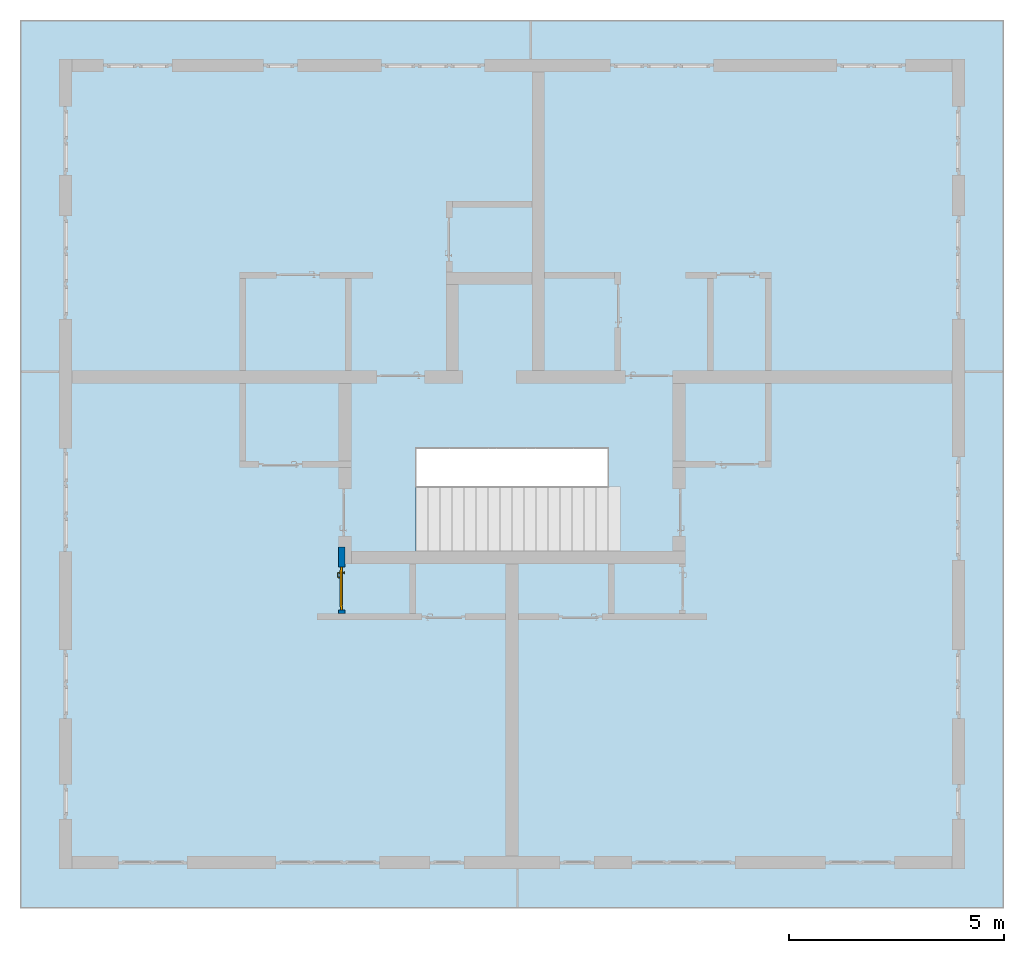
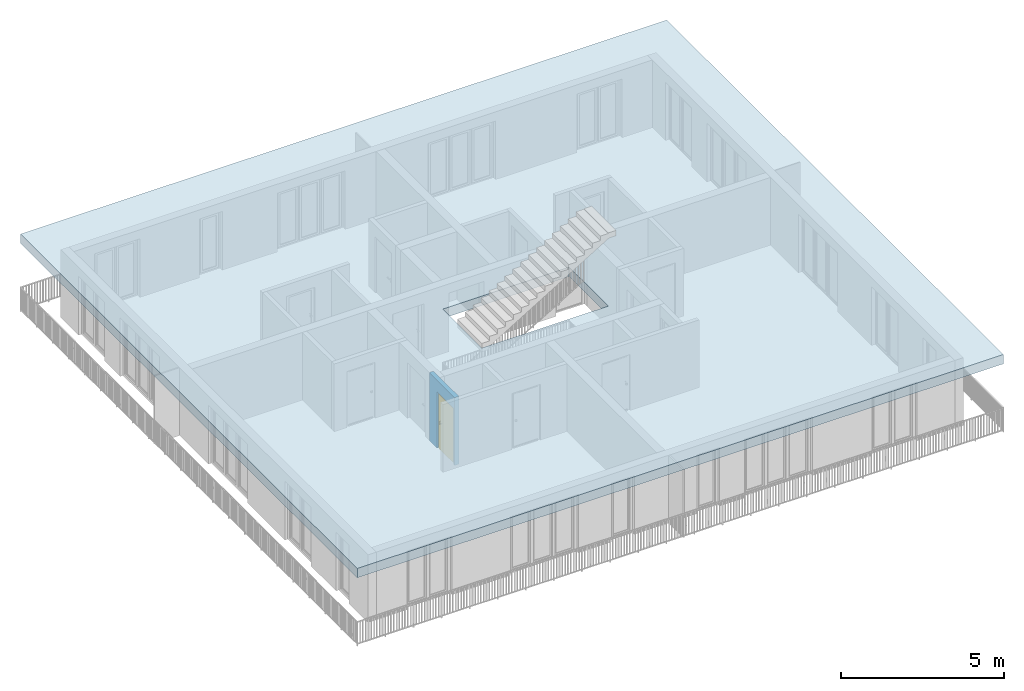
# One storey, part 1 of 48: 1 door, 1 slab, 1 wall, 1 opening.
"""IFC4 building model written with IfcOpenShell, lengths in metres."""

from ifc_helpers import new_model, entity, si_unit, converted_unit, derived_unit, direction, frame, origin_with_axes, place, context, subcontext, project, spatial, polygons, source, transform, mapped, material, type_object, element, fill, save


model = new_model("IFC4")

# Units and contexts
model_context = context("Model", 3, precision=1e-05, world=origin_with_axes(), true_north=direction((0.0, 1.0)))
body_context = subcontext(model_context, "Body", "Model", "MODEL_VIEW")
ifc_project = project(units=[si_unit("LENGTHUNIT", "METRE"), si_unit("AREAUNIT", "SQUARE_METRE"), si_unit("VOLUMEUNIT", "CUBIC_METRE"), converted_unit("PLANEANGLEUNIT", "DEGREE", entity("IfcPlaneAngleMeasure", 0.0174532925199), si_unit("PLANEANGLEUNIT", "RADIAN"), dimensions=[0, 0, 0, 0, 0, 0, 0]), converted_unit("TIMEUNIT", "Year", entity("IfcTimeMeasure", 31556926.0), si_unit("TIMEUNIT", "SECOND"), dimensions=[0, 0, 1, 0, 0, 0, 0]), si_unit("MASSUNIT", "GRAM", prefix="KILO"), si_unit("THERMODYNAMICTEMPERATUREUNIT", "DEGREE_CELSIUS"), si_unit("LUMINOUSINTENSITYUNIT", "LUMEN"), si_unit("ENERGYUNIT", "JOULE", prefix="MEGA"), derived_unit("THERMALCONDUCTANCEUNIT", [(si_unit("POWERUNIT", "WATT"), 1), (si_unit("LENGTHUNIT", "METRE"), -1), (si_unit("THERMODYNAMICTEMPERATUREUNIT", "KELVIN"), -1)]), derived_unit("SPECIFICHEATCAPACITYUNIT", [(si_unit("ENERGYUNIT", "JOULE"), 1), (si_unit("MASSUNIT", "GRAM", prefix="KILO"), -1), (si_unit("THERMODYNAMICTEMPERATUREUNIT", "KELVIN"), -1)]), derived_unit("MASSDENSITYUNIT", [(si_unit("MASSUNIT", "GRAM", prefix="KILO"), 1), (si_unit("VOLUMEUNIT", "CUBIC_METRE"), -1)])], contexts=[model_context])

# Site, building, storey, space
site_placement = place(None, origin_with_axes())
site = spatial("IfcSite", under=ifc_project, at=site_placement, CompositionType="ELEMENT")
building_placement = place(site_placement, origin_with_axes())
building = spatial("IfcBuilding", under=site, at=building_placement, CompositionType="ELEMENT")
storey_placement = place(building_placement, frame((0.0, 0.0, 3.4), z_axis=(0.0, 0.0, 1.0), x_axis=(1.0, 0.0, 0.0)))
storey = spatial("IfcBuildingStorey", under=building, at=storey_placement, Name="1. Geschoss", CompositionType="ELEMENT", Elevation=3.4)
space_placement = place(storey_placement, frame((-0.742199380397, 1.67118776896, 0.0), z_axis=(0.0, 0.0, 1.0), x_axis=(0.0, 1.0, 0.0)))
space = spatial("IfcSpace", under=storey, at=space_placement, CompositionType="ELEMENT", PredefinedType="INTERNAL")

# Slab
ifc_material = material()
slab_type = type_object("IfcSlabType", Name="350", PredefinedType="NOTDEFINED")
slab_placement = place(space_placement, frame((-12.5, 11.9, 2.89), z_axis=(0.0, 0.0, 1.0), x_axis=(0.0, -1.0, 0.0)))
element("IfcSlab", 1, at=slab_placement, inside=space, type_object=slab_type, material=ifc_material, Name="Decke-001", PredefinedType="NOTDEFINED", context=body_context, shape_type="Tessellation", body=[
    polygons([(0.0, 0.0, 0.0), (0.0, 0.0, -0.35), (22.88, 0.0, -0.35), (22.88, 0.0, 0.0), (0.0, 20.65, 0.0), (0.0, 20.65, -0.35), (22.88, 20.65, -0.35), (13.68, 8.3, -0.35), (13.68, 10.7, -0.35), (9.2, 10.7, -0.35), (9.2, 8.3, -0.35), (22.88, 20.65, 0.0), (9.2, 10.7, 0.0), (13.68, 10.7, 0.0), (13.68, 8.3, 0.0), (9.2, 8.3, 0.0)], [[[1, 2, 3, 4]], [[5, 6, 2, 1]], [[3, 2, 6, 7], [8, 9, 10, 11]], [[4, 3, 7, 12]], [[5, 1, 4, 12], [13, 14, 15, 16]], [[12, 7, 6, 5]], [[14, 9, 8, 15]], [[13, 10, 9, 14]], [[16, 11, 10, 13]], [[15, 8, 11, 16]]], closed=True),
])

# Wall, opening, door
wall_type = type_object("IfcWallType", Name="150", PredefinedType="NOTDEFINED")
wall_placement = place(storey_placement, frame((-5.2421993804, -4.12881223104, 0.0), z_axis=(0.0, 0.0, 1.0), x_axis=(0.0, 1.0, 0.0)))
wall = element("IfcWall", 2, at=wall_placement, inside=storey, type_object=wall_type, material=ifc_material, Name="Wand-002", PredefinedType="NOTDEFINED", context=body_context, shape_type="Tessellation", body=[
    polygons([(0.225, -0.15, 2.1), (0.225, 0.0, 2.1), (1.225, 0.0, 2.1), (1.225, -0.15, 2.1), (0.225, -0.1, 0.0), (0.225, 0.0, 0.0), (0.225, -0.15, 0.0), (0.15, 0.0, 0.0), (0.15, 0.0, 2.54), (1.7, 0.0, 2.54), (1.7, 0.0, 0.0), (1.225, 0.0, 0.0), (1.225, -0.1, 0.0), (1.225, -0.15, 0.0), (1.7, -0.15, 2.54), (0.15, -0.15, 2.54), (0.15, -0.15, 0.0), (1.7, -0.15, 0.0)], [[[1, 2, 3, 4]], [[5, 6, 2, 1, 7]], [[2, 6, 8, 9, 10, 11, 12, 3]], [[4, 3, 12, 13, 14]], [[15, 16, 17, 7, 1, 4, 14, 18]], [[6, 5, 7, 17, 8]], [[9, 8, 17, 16]], [[15, 10, 9, 16]], [[15, 18, 11, 10]], [[13, 12, 11, 18, 14]]], closed=True),
])
opening_placement = place(wall_placement, frame((0.725, 0.0, 0.0), z_axis=(0.0, 0.0, 1.0), x_axis=(1.0, 0.0, 0.0)))
opening = element("IfcOpeningElement", 3, at=opening_placement, cuts=wall, context=body_context, identifier="Reference", shape_type="Tessellation", body=[
    polygons([(0.5, -0.1, 0.0), (0.5, -0.1, 2.1), (0.5, -0.151, 2.1), (0.5, -0.151, 0.0), (0.5, 0.001, 0.0), (0.5, 0.001, 2.1), (-0.5, -0.1, 2.1), (-0.5, -0.151, 2.1), (-0.5, 0.001, 2.1), (-0.5, -0.151, 0.0), (-0.5, -0.1, 0.0), (-0.5, 0.001, 0.0)], [[[1, 2, 3, 4]], [[2, 1, 5, 6]], [[7, 8, 3, 2, 6, 9]], [[8, 10, 4, 3]], [[1, 4, 10, 11, 12, 5]], [[6, 5, 12, 9]], [[7, 11, 10, 8]], [[11, 7, 9, 12]]], closed=True),
])
door_type = type_object("IfcDoorType", Name="Eingang 01 1-Fl 26", OperationType="SINGLE_SWING_LEFT", PredefinedType="DOOR")
shared_shape = source(origin_with_axes(), body_context, "Body", "Tessellation", [
    polygons([(-0.5, -0.05, 0.0), (-0.5, -0.05, 2.1), (-0.5, -0.03, 2.1), (-0.5, -0.03, 0.0), (-0.4, -0.05, 0.0), (-0.4, -0.05, 2.0), (-0.1301, -0.05, 2.0), (-0.0001, -0.05, 2.0), (0.4, -0.05, 2.0), (0.4, -0.05, 0.0), (0.5, -0.05, 0.0), (0.5, -0.05, 2.1), (0.5, -0.03, 2.1), (0.5, -0.03, 0.0), (0.4, -0.03, 0.0), (0.4, -0.03, 2.0), (-0.0001, -0.03, 2.0), (-0.1301, -0.03, 2.0), (-0.4, -0.03, 2.0), (-0.4, -0.03, 0.0)], [[[1, 2, 3, 4]], [[1, 5, 6, 7, 8, 9, 10, 11, 12, 2]], [[2, 12, 13, 3]], [[4, 3, 13, 14, 15, 16, 17, 18, 19, 20]], [[5, 1, 4, 20]], [[6, 5, 20, 19]], [[7, 6, 19, 18]], [[8, 7, 18, 17]], [[9, 8, 17, 16]], [[10, 9, 16, 15]], [[11, 10, 15, 14]], [[12, 11, 14, 13]]], closed=True),
    polygons([(-0.5, -0.03, 0.0), (-0.5, -0.03, 2.1), (-0.5, 0.0, 2.1), (-0.5, 0.0, 0.0), (-0.43, -0.03, 0.0), (-0.43, -0.03, 2.03), (-0.1001, -0.03, 2.03), (-0.0301, -0.03, 2.03), (0.43, -0.03, 2.03), (0.43, -0.03, 0.0), (0.5, -0.03, 0.0), (0.5, -0.03, 2.1), (0.5, 0.0, 2.1), (0.5, 0.0, 0.0), (0.43, 0.0, 0.0), (0.43, 0.0, 2.03), (-0.0301, 0.0, 2.03), (-0.1001, 0.0, 2.03), (-0.43, 0.0, 2.03), (-0.43, 0.0, 0.0)], [[[1, 2, 3, 4]], [[1, 5, 6, 7, 8, 9, 10, 11, 12, 2]], [[2, 12, 13, 3]], [[4, 3, 13, 14, 15, 16, 17, 18, 19, 20]], [[5, 1, 4, 20]], [[6, 5, 20, 19]], [[7, 6, 19, 18]], [[8, 7, 18, 17]], [[9, 8, 17, 16]], [[10, 9, 16, 15]], [[11, 10, 15, 14]], [[12, 11, 14, 13]]], closed=True),
    polygons([(-0.43, 0.01, 0.0), (-0.43, 0.01, 2.03), (0.43, 0.01, 2.03), (0.43, 0.01, 0.0), (-0.43, -0.03, 0.0), (-0.43, -0.03, 2.03), (0.43, -0.03, 2.03), (0.43, -0.03, 0.0)], [[[1, 2, 3, 4]], [[1, 5, 6, 2]], [[2, 6, 7, 3]], [[3, 7, 8, 4]], [[4, 8, 5, 1]], [[8, 7, 6, 5]]], closed=True),
    polygons([(-0.395, -0.05, 0.0), (0.395, -0.05, 0.0), (0.395, -0.05, 0.05), (-0.395, -0.05, 0.05), (-0.395, -0.03, 0.0), (0.395, -0.03, 0.0), (0.395, -0.03, 0.07), (0.395, -0.035, 0.07), (-0.395, -0.035, 0.07), (-0.395, -0.03, 0.07)], [[[1, 2, 3, 4]], [[5, 6, 2, 1]], [[2, 6, 7, 8, 3]], [[4, 3, 8, 9]], [[1, 4, 9, 10, 5]], [[10, 7, 6, 5]], [[9, 8, 7, 10]]], closed=True),
    polygons([(0.3835, 0.02, 1.0733826859), (0.37, 0.02, 1.077), (0.37, 0.0199, 1.077), (0.3835, 0.0199, 1.0733826859), (0.393382685902, 0.02, 1.0635), (0.397, 0.02, 1.05), (0.393382685902, 0.02, 1.0365), (0.3835, 0.02, 1.0266173141), (0.37, 0.02, 1.023), (0.3565, 0.02, 1.0266173141), (0.346617314098, 0.02, 1.0365), (0.343, 0.02, 1.05), (0.346617314098, 0.02, 1.0635), (0.3565, 0.02, 1.0733826859), (0.3565, 0.0199, 1.0733826859), (0.37, 0.0101, 1.077), (0.3835, 0.0101, 1.0733826859), (0.393382685902, 0.0199, 1.0635), (0.397, 0.0199, 1.05), (0.393382685902, 0.0199, 1.0365), (0.3835, 0.0199, 1.0266173141), (0.37, 0.0199, 1.023), (0.3565, 0.0199, 1.0266173141), (0.346617314098, 0.0199, 1.0365), (0.343, 0.0199, 1.05), (0.346617314098, 0.0199, 1.0635), (0.3565, 0.0101, 1.0733826859), (0.37, 0.01, 1.077), (0.3835, 0.01, 1.0733826859), (0.393382685902, 0.0101, 1.0635), (0.397, 0.0101, 1.05), (0.393382685902, 0.0101, 1.0365), (0.3835, 0.0101, 1.0266173141), (0.37, 0.0101, 1.023), (0.3565, 0.0101, 1.0266173141), (0.346617314098, 0.0101, 1.0365), (0.343, 0.0101, 1.05), (0.346617314098, 0.0101, 1.0635), (0.3565, 0.01, 1.0733826859), (0.346617314098, 0.01, 1.0635), (0.343, 0.01, 1.05), (0.346617314098, 0.01, 1.0365), (0.3565, 0.01, 1.0266173141), (0.37, 0.01, 1.023), (0.3835, 0.01, 1.0266173141), (0.393382685902, 0.01, 1.0365), (0.397, 0.01, 1.05), (0.393382685902, 0.01, 1.0635)], [[[1, 2, 3, 4]], [[2, 1, 5, 6, 7, 8, 9, 10, 11, 12, 13, 14]], [[2, 14, 15, 3]], [[4, 3, 16, 17]], [[5, 1, 4, 18]], [[6, 5, 18, 19]], [[7, 6, 19, 20]], [[8, 7, 20, 21]], [[9, 8, 21, 22]], [[10, 9, 22, 23]], [[11, 10, 23, 24]], [[12, 11, 24, 25]], [[13, 12, 25, 26]], [[14, 13, 26, 15]], [[3, 15, 27, 16]], [[17, 16, 28, 29]], [[18, 4, 17, 30]], [[19, 18, 30, 31]], [[20, 19, 31, 32]], [[21, 20, 32, 33]], [[22, 21, 33, 34]], [[23, 22, 34, 35]], [[24, 23, 35, 36]], [[25, 24, 36, 37]], [[26, 25, 37, 38]], [[15, 26, 38, 27]], [[16, 27, 39, 28]], [[28, 39, 40, 41, 42, 43, 44, 45, 46, 47, 48, 29]], [[30, 17, 29, 48]], [[31, 30, 48, 47]], [[32, 31, 47, 46]], [[33, 32, 46, 45]], [[34, 33, 45, 44]], [[35, 34, 44, 43]], [[36, 35, 43, 42]], [[37, 36, 42, 41]], [[38, 37, 41, 40]], [[27, 38, 40, 39]]], closed=True),
    polygons([(0.362532169224, 0.019, 0.959692280177), (0.363279754556, 0.019, 0.961639806549), (0.35705, 0.019, 0.972430057958), (0.347569942042, 0.019, 0.96295), (0.365, 0.019, 0.952886751346), (0.365, 0.019, 0.9544), (0.362532169224, 0.02, 0.959692280177), (0.363279754556, 0.02, 0.961639806549), (0.364624817685, 0.02, 0.965143815798), (0.364624817685, 0.019, 0.965143815798), (0.37, 0.019, 0.967425445323), (0.37, 0.019, 0.9759), (0.357, 0.019, 0.972516660498), (0.347483339502, 0.019, 0.963), (0.365, 0.019, 0.95), (0.3441, 0.019, 0.95), (0.365, 0.019, 0.947113248654), (0.365, 0.019, 0.941339745962), (0.365, 0.019, 0.9375), (0.365, 0.02, 0.9375), (0.365, 0.02, 0.941339745962), (0.365, 0.02, 0.947113248654), (0.365, 0.02, 0.95), (0.365, 0.02, 0.952886751346), (0.365, 0.02, 0.9544), (0.346703916638, 0.02, 0.96345), (0.35655, 0.02, 0.973296083362), (0.37, 0.02, 0.9769), (0.37, 0.02, 0.967425445323), (0.375375182315, 0.019, 0.965143815798), (0.376720245444, 0.019, 0.961639806549), (0.38295, 0.019, 0.972430057958), (0.37, 0.019, 0.976), (0.357, 0.0189, 0.972516660498), (0.347483339502, 0.0189, 0.963), (0.344, 0.019, 0.95), (0.347569942042, 0.019, 0.93705), (0.35705, 0.019, 0.927569942042), (0.37, 0.019, 0.9241), (0.37, 0.019, 0.9325), (0.366464466094, 0.019, 0.933964466094), (0.366464466094, 0.02, 0.933964466094), (0.37, 0.02, 0.9231), (0.35655, 0.02, 0.926703916638), (0.37, 0.02, 0.9325), (0.346703916638, 0.02, 0.93655), (0.3431, 0.02, 0.95), (0.346617314098, 0.02, 0.9635), (0.3565, 0.02, 0.973382685902), (0.37, 0.02, 0.977), (0.375375182315, 0.02, 0.965143815798), (0.38345, 0.02, 0.973296083362), (0.376720245444, 0.02, 0.961639806549), (0.377467830776, 0.02, 0.959692280177), (0.377467830776, 0.019, 0.959692280177), (0.375, 0.019, 0.9544), (0.375, 0.019, 0.952886751346), (0.392430057958, 0.019, 0.96295), (0.383, 0.019, 0.972516660498), (0.37, 0.0189, 0.976), (0.357, 0.0101, 0.972516660498), (0.347483339502, 0.0101, 0.963), (0.344, 0.0189, 0.95), (0.347483339502, 0.019, 0.937), (0.357, 0.019, 0.927483339502), (0.37, 0.019, 0.924), (0.38295, 0.019, 0.927569942042), (0.375, 0.019, 0.941339745962), (0.375, 0.019, 0.9375), (0.373535533906, 0.019, 0.933964466094), (0.37, 0.02, 0.923), (0.3565, 0.02, 0.926617314098), (0.38345, 0.02, 0.926703916638), (0.373535533906, 0.02, 0.933964466094), (0.375, 0.02, 0.9375), (0.375, 0.02, 0.941339745962), (0.346617314098, 0.02, 0.9365), (0.343, 0.02, 0.95), (0.346617314098, 0.0199, 0.9635), (0.3565, 0.0199, 0.973382685902), (0.37, 0.0199, 0.977), (0.3835, 0.02, 0.973382685902), (0.393296083362, 0.02, 0.96345), (0.375, 0.02, 0.952886751346), (0.375, 0.02, 0.9544), (0.375, 0.02, 0.95), (0.375, 0.02, 0.947113248654), (0.375, 0.019, 0.947113248654), (0.375, 0.019, 0.95), (0.3959, 0.019, 0.95), (0.392516660498, 0.019, 0.963), (0.383, 0.0189, 0.972516660498), (0.37, 0.0101, 0.976), (0.357, 0.01, 0.972516660498), (0.347483339502, 0.01, 0.963), (0.344, 0.0101, 0.95), (0.347483339502, 0.0189, 0.937), (0.357, 0.0189, 0.927483339502), (0.37, 0.0189, 0.924), (0.383, 0.019, 0.927483339502), (0.392430057958, 0.019, 0.93705), (0.37, 0.0199, 0.923), (0.3565, 0.0199, 0.926617314098), (0.3835, 0.02, 0.926617314098), (0.393296083362, 0.02, 0.93655), (0.346617314098, 0.0199, 0.9365), (0.343, 0.0199, 0.95), (0.346617314098, 0.0101, 0.9635), (0.3565, 0.0101, 0.973382685902), (0.37, 0.0101, 0.977), (0.3835, 0.0199, 0.973382685902), (0.393382685902, 0.02, 0.9635), (0.3969, 0.02, 0.95), (0.396, 0.019, 0.95), (0.392516660498, 0.0189, 0.963), (0.383, 0.0101, 0.972516660498), (0.37, 0.01, 0.976), (0.35695, 0.01, 0.972603263039), (0.347396736961, 0.01, 0.96305), (0.344, 0.01, 0.95), (0.347483339502, 0.0101, 0.937), (0.357, 0.0101, 0.927483339502), (0.37, 0.0101, 0.924), (0.383, 0.0189, 0.927483339502), (0.392516660498, 0.019, 0.937), (0.37, 0.0101, 0.923), (0.3565, 0.0101, 0.926617314098), (0.3835, 0.0199, 0.926617314098), (0.393382685902, 0.02, 0.9365), (0.346617314098, 0.0101, 0.9365), (0.343, 0.0101, 0.95), (0.346617314098, 0.01, 0.9635), (0.3565, 0.01, 0.973382685902), (0.37, 0.01, 0.977), (0.3835, 0.0101, 0.973382685902), (0.393382685902, 0.0199, 0.9635), (0.397, 0.02, 0.95), (0.396, 0.0189, 0.95), (0.392516660498, 0.0101, 0.963), (0.383, 0.01, 0.972516660498), (0.37, 0.01, 0.9761), (0.35655, 0.01, 0.973296083362), (0.346703916638, 0.01, 0.96345), (0.3439, 0.01, 0.95), (0.347483339502, 0.01, 0.937), (0.357, 0.01, 0.927483339502), (0.37, 0.01, 0.924), (0.383, 0.0101, 0.927483339502), (0.392516660498, 0.0189, 0.937), (0.37, 0.01, 0.923), (0.3565, 0.01, 0.926617314098), (0.3835, 0.0101, 0.926617314098), (0.393382685902, 0.0199, 0.9365), (0.346617314098, 0.01, 0.9365), (0.343, 0.01, 0.95), (0.37, 0.01, 0.9769), (0.3835, 0.01, 0.973382685902), (0.393382685902, 0.0101, 0.9635), (0.397, 0.0199, 0.95), (0.396, 0.0101, 0.95), (0.392516660498, 0.01, 0.963), (0.38305, 0.01, 0.972603263039), (0.3431, 0.01, 0.95), (0.347396736961, 0.01, 0.93695), (0.35695, 0.01, 0.927396736961), (0.37, 0.01, 0.9239), (0.383, 0.01, 0.927483339502), (0.392516660498, 0.0101, 0.937), (0.37, 0.01, 0.9231), (0.35655, 0.01, 0.926703916638), (0.3835, 0.01, 0.926617314098), (0.393382685902, 0.0101, 0.9365), (0.346703916638, 0.01, 0.93655), (0.38345, 0.01, 0.973296083362), (0.393382685902, 0.01, 0.9635), (0.397, 0.0101, 0.95), (0.396, 0.01, 0.95), (0.392603263039, 0.01, 0.96305), (0.38305, 0.01, 0.927396736961), (0.392516660498, 0.01, 0.937), (0.38345, 0.01, 0.926703916638), (0.393382685902, 0.01, 0.9365), (0.393296083362, 0.01, 0.96345), (0.397, 0.01, 0.95), (0.3961, 0.01, 0.95), (0.392603263039, 0.01, 0.93695), (0.393296083362, 0.01, 0.93655), (0.3969, 0.01, 0.95)], [[[1, 2, 3, 4, 5, 6]], [[1, 7, 8, 9, 10, 2]], [[10, 11, 12, 3, 2]], [[4, 3, 13, 14]], [[15, 5, 4, 16]], [[6, 5, 15, 17, 18, 19, 20, 21, 22, 23, 24, 25]], [[6, 25, 7, 1]], [[7, 25, 24, 26, 27, 8]], [[9, 8, 27, 28, 29]], [[10, 9, 29, 11]], [[30, 31, 32, 12, 11]], [[3, 12, 33, 13]], [[14, 13, 34, 35]], [[16, 4, 14, 36]], [[17, 15, 16, 37]], [[18, 17, 37, 38]], [[38, 39, 40, 41, 19, 18]], [[19, 41, 42, 20]], [[43, 44, 21, 20, 42, 45]], [[22, 21, 44, 46]], [[23, 22, 46, 47]], [[24, 23, 47, 26]], [[48, 49, 27, 26]], [[49, 50, 28, 27]], [[51, 29, 28, 52, 53]], [[11, 29, 51, 30]], [[30, 51, 53, 54, 55, 31]], [[55, 56, 57, 58, 32, 31]], [[12, 32, 59, 33]], [[13, 33, 60, 34]], [[35, 34, 61, 62]], [[36, 14, 35, 63]], [[37, 16, 36, 64]], [[38, 37, 64, 65]], [[39, 38, 65, 66]], [[39, 67, 68, 69, 70, 40]], [[41, 40, 45, 42]], [[71, 72, 44, 43]], [[73, 43, 45, 74, 75, 76]], [[72, 77, 46, 44]], [[77, 78, 47, 46]], [[78, 48, 26, 47]], [[79, 80, 49, 48]], [[80, 81, 50, 49]], [[50, 82, 52, 28]], [[54, 53, 52, 83, 84, 85]], [[55, 54, 85, 56]], [[85, 84, 86, 87, 76, 75, 69, 68, 88, 89, 57, 56]], [[57, 89, 90, 58]], [[32, 58, 91, 59]], [[33, 59, 92, 60]], [[34, 60, 93, 61]], [[62, 61, 94, 95]], [[63, 35, 62, 96]], [[64, 36, 63, 97]], [[65, 64, 97, 98]], [[66, 65, 98, 99]], [[67, 39, 66, 100]], [[88, 68, 67, 101]], [[70, 69, 75, 74]], [[40, 70, 74, 45]], [[102, 103, 72, 71]], [[104, 71, 43, 73]], [[76, 87, 105, 73]], [[103, 106, 77, 72]], [[106, 107, 78, 77]], [[107, 79, 48, 78]], [[108, 109, 80, 79]], [[109, 110, 81, 80]], [[81, 111, 82, 50]], [[82, 112, 83, 52]], [[86, 84, 83, 113]], [[87, 86, 113, 105]], [[89, 88, 101, 90]], [[58, 90, 114, 91]], [[59, 91, 115, 92]], [[60, 92, 116, 93]], [[61, 93, 117, 94]], [[95, 94, 118, 119]], [[96, 62, 95, 120]], [[97, 63, 96, 121]], [[98, 97, 121, 122]], [[99, 98, 122, 123]], [[100, 66, 99, 124]], [[101, 67, 100, 125]], [[126, 127, 103, 102]], [[128, 102, 71, 104]], [[129, 104, 73, 105]], [[127, 130, 106, 103]], [[130, 131, 107, 106]], [[131, 108, 79, 107]], [[132, 133, 109, 108]], [[133, 134, 110, 109]], [[110, 135, 111, 81]], [[111, 136, 112, 82]], [[112, 137, 113, 83]], [[137, 129, 105, 113]], [[90, 101, 125, 114]], [[91, 114, 138, 115]], [[92, 115, 139, 116]], [[93, 116, 140, 117]], [[94, 117, 141, 118]], [[119, 118, 142, 143]], [[120, 95, 119, 144]], [[121, 96, 120, 145]], [[122, 121, 145, 146]], [[123, 122, 146, 147]], [[124, 99, 123, 148]], [[125, 100, 124, 149]], [[150, 151, 127, 126]], [[152, 126, 102, 128]], [[153, 128, 104, 129]], [[151, 154, 130, 127]], [[154, 155, 131, 130]], [[155, 132, 108, 131]], [[143, 142, 133, 132]], [[142, 156, 134, 133]], [[134, 157, 135, 110]], [[135, 158, 136, 111]], [[136, 159, 137, 112]], [[159, 153, 129, 137]], [[114, 125, 149, 138]], [[115, 138, 160, 139]], [[116, 139, 161, 140]], [[117, 140, 162, 141]], [[118, 141, 156, 142]], [[144, 119, 143, 163]], [[145, 120, 144, 164]], [[146, 145, 164, 165]], [[147, 146, 165, 166]], [[148, 123, 147, 167]], [[149, 124, 148, 168]], [[169, 170, 151, 150]], [[171, 150, 126, 152]], [[172, 152, 128, 153]], [[170, 173, 154, 151]], [[173, 163, 155, 154]], [[163, 143, 132, 155]], [[156, 174, 157, 134]], [[157, 175, 158, 135]], [[158, 176, 159, 136]], [[176, 172, 153, 159]], [[138, 149, 168, 160]], [[139, 160, 177, 161]], [[140, 161, 178, 162]], [[141, 162, 174, 156]], [[164, 144, 163, 173]], [[165, 164, 173, 170]], [[166, 165, 170, 169]], [[167, 147, 166, 179]], [[168, 148, 167, 180]], [[181, 169, 150, 171]], [[182, 171, 152, 172]], [[174, 183, 175, 157]], [[175, 184, 176, 158]], [[184, 182, 172, 176]], [[160, 168, 180, 177]], [[161, 177, 185, 178]], [[162, 178, 183, 174]], [[179, 166, 169, 181]], [[180, 167, 179, 186]], [[187, 181, 171, 182]], [[183, 188, 184, 175]], [[188, 187, 182, 184]], [[177, 180, 186, 185]], [[178, 185, 188, 183]], [[186, 179, 181, 187]], [[185, 186, 187, 188]]], closed=True),
    polygons([(0.38, 0.02, 1.05), (0.377071067812, 0.02, 1.04292893219), (0.377071067812, 0.050696439392, 1.04292893219), (0.38, 0.0509849140336, 1.05), (0.37, 0.02, 1.04), (0.37, 0.05, 1.04), (0.375518993221, 0.0584992452783, 1.04292893219), (0.378277987014, 0.0596420579258, 1.05), (0.377071067812, 0.02, 1.05707106781), (0.377071067812, 0.050696439392, 1.05707106781), (0.362928932188, 0.02, 1.04292893219), (0.362928932188, 0.049303560608, 1.04292893219), (0.368858192988, 0.0557402514855, 1.04), (0.370704557509, 0.0657045575088, 1.04292893219), (0.372816199938, 0.0678161999379, 1.05), (0.375518993221, 0.0584992452783, 1.05707106781), (0.37, 0.02, 1.06), (0.37, 0.05, 1.06), (0.36, 0.02, 1.05), (0.36, 0.0490150859664, 1.05), (0.362197392755, 0.0529812576926, 1.04292893219), (0.365606601718, 0.0606066017178, 1.04), (0.363499245278, 0.0705189932208, 1.04292893219), (0.364642057926, 0.0732779870137, 1.05), (0.370704557509, 0.0657045575088, 1.05707106781), (0.368858192988, 0.0557402514855, 1.06), (0.362928932188, 0.02, 1.05707106781), (0.362928932188, 0.049303560608, 1.05707106781), (0.359438398962, 0.0518384450452, 1.05), (0.360508645927, 0.0555086459268, 1.04292893219), (0.360740251485, 0.0638581929877, 1.04), (0.355696439392, 0.0720710678119, 1.04292893219), (0.355984914034, 0.075, 1.05), (0.363499245278, 0.0705189932208, 1.05707106781), (0.365606601718, 0.0606066017178, 1.06), (0.362197392755, 0.0529812576926, 1.05707106781), (0.358397003498, 0.0533970034977, 1.05), (0.357981257693, 0.0571973927545, 1.04292893219), (0.355, 0.065, 1.04), (0.274303560608, 0.0720710678119, 1.04292893219), (0.274015085966, 0.075, 1.05), (0.355696439392, 0.0720710678119, 1.05707106781), (0.360740251485, 0.0638581929877, 1.06), (0.360508645927, 0.0555086459268, 1.05707106781), (0.356838445045, 0.0544383989617, 1.05), (0.354303560608, 0.0579289321881, 1.04292893219), (0.275, 0.065, 1.04), (0.266500754722, 0.0705189932208, 1.04292893219), (0.265357942074, 0.0732779870137, 1.05), (0.274303560608, 0.0720710678119, 1.05707106781), (0.355, 0.065, 1.06), (0.357981257693, 0.0571973927545, 1.05707106781), (0.354015085966, 0.055, 1.05), (0.275696439392, 0.0579289321881, 1.04292893219), (0.269259748515, 0.0638581929877, 1.04), (0.259295442491, 0.0657045575088, 1.04292893219), (0.257183800062, 0.0678161999379, 1.05), (0.266500754722, 0.0705189932208, 1.05707106781), (0.275, 0.065, 1.06), (0.354303560608, 0.0579289321881, 1.05707106781), (0.275984914034, 0.055, 1.05), (0.272018742307, 0.0571973927545, 1.04292893219), (0.264393398282, 0.0606066017178, 1.04), (0.254481006779, 0.0584992452783, 1.04292893219), (0.251722012986, 0.0596420579258, 1.05), (0.259295442491, 0.0657045575088, 1.05707106781), (0.269259748515, 0.0638581929877, 1.06), (0.275696439392, 0.0579289321881, 1.05707106781), (0.273161554955, 0.0544383989617, 1.05), (0.269491354073, 0.0555086459268, 1.04292893219), (0.261141807012, 0.0557402514855, 1.04), (0.252928932188, 0.050696439392, 1.04292893219), (0.25, 0.0509849140336, 1.05), (0.254481006779, 0.0584992452783, 1.05707106781), (0.264393398282, 0.0606066017178, 1.06), (0.272018742307, 0.0571973927545, 1.05707106781), (0.271602996502, 0.0533970034977, 1.05), (0.267802607245, 0.0529812576926, 1.04292893219), (0.26, 0.05, 1.04), (0.252928932188, 0.02, 1.04292893219), (0.25, 0.02, 1.05), (0.252928932188, 0.050696439392, 1.05707106781), (0.261141807012, 0.0557402514855, 1.06), (0.269491354073, 0.0555086459268, 1.05707106781), (0.270561601038, 0.0518384450452, 1.05), (0.267071067812, 0.049303560608, 1.04292893219), (0.26, 0.02, 1.04), (0.267071067812, 0.02, 1.04292893219), (0.27, 0.02, 1.05), (0.267071067812, 0.02, 1.05707106781), (0.26, 0.02, 1.06), (0.252928932188, 0.02, 1.05707106781), (0.26, 0.05, 1.06), (0.267802607245, 0.0529812576926, 1.05707106781), (0.27, 0.0490150859664, 1.05), (0.267071067812, 0.049303560608, 1.05707106781)], [[[1, 2, 3, 4]], [[2, 5, 6, 3]], [[4, 3, 7, 8]], [[9, 1, 4, 10]], [[5, 11, 12, 6]], [[3, 6, 13, 7]], [[8, 7, 14, 15]], [[10, 4, 8, 16]], [[17, 9, 10, 18]], [[11, 19, 20, 12]], [[6, 12, 21, 13]], [[7, 13, 22, 14]], [[15, 14, 23, 24]], [[16, 8, 15, 25]], [[18, 10, 16, 26]], [[27, 17, 18, 28]], [[19, 27, 28, 20]], [[12, 20, 29, 21]], [[13, 21, 30, 22]], [[14, 22, 31, 23]], [[24, 23, 32, 33]], [[25, 15, 24, 34]], [[26, 16, 25, 35]], [[28, 18, 26, 36]], [[20, 28, 36, 29]], [[21, 29, 37, 30]], [[22, 30, 38, 31]], [[23, 31, 39, 32]], [[33, 32, 40, 41]], [[34, 24, 33, 42]], [[35, 25, 34, 43]], [[36, 26, 35, 44]], [[29, 36, 44, 37]], [[30, 37, 45, 38]], [[31, 38, 46, 39]], [[32, 39, 47, 40]], [[41, 40, 48, 49]], [[42, 33, 41, 50]], [[43, 34, 42, 51]], [[44, 35, 43, 52]], [[37, 44, 52, 45]], [[38, 45, 53, 46]], [[39, 46, 54, 47]], [[40, 47, 55, 48]], [[49, 48, 56, 57]], [[50, 41, 49, 58]], [[51, 42, 50, 59]], [[52, 43, 51, 60]], [[45, 52, 60, 53]], [[46, 53, 61, 54]], [[47, 54, 62, 55]], [[48, 55, 63, 56]], [[57, 56, 64, 65]], [[58, 49, 57, 66]], [[59, 50, 58, 67]], [[60, 51, 59, 68]], [[53, 60, 68, 61]], [[54, 61, 69, 62]], [[55, 62, 70, 63]], [[56, 63, 71, 64]], [[65, 64, 72, 73]], [[66, 57, 65, 74]], [[67, 58, 66, 75]], [[68, 59, 67, 76]], [[61, 68, 76, 69]], [[62, 69, 77, 70]], [[63, 70, 78, 71]], [[64, 71, 79, 72]], [[73, 72, 80, 81]], [[74, 65, 73, 82]], [[75, 66, 74, 83]], [[76, 67, 75, 84]], [[69, 76, 84, 77]], [[70, 77, 85, 78]], [[71, 78, 86, 79]], [[72, 79, 87, 80]], [[81, 80, 87, 88, 89, 90, 91, 92]], [[82, 73, 81, 92]], [[83, 74, 82, 93]], [[84, 75, 83, 94]], [[77, 84, 94, 85]], [[78, 85, 95, 86]], [[79, 86, 88, 87]], [[86, 95, 89, 88]], [[95, 96, 90, 89]], [[96, 93, 91, 90]], [[93, 82, 92, 91]], [[94, 83, 93, 96]], [[85, 94, 96, 95]]], closed=False),
    polygons([(0.364696699141, -0.035, 1.04469669914), (0.3625, -0.035, 1.05), (0.364696699141, -0.035, 1.05530330086), (0.37, -0.035, 1.0575), (0.375303300859, -0.035, 1.05530330086), (0.3775, -0.035, 1.05), (0.375303300859, -0.035, 1.04469669914), (0.37, -0.035, 1.0425), (0.364696699141, -0.075, 1.04469669914), (0.3625, -0.075, 1.05), (0.364696699141, -0.075, 1.05530330086), (0.37, -0.075, 1.0575), (0.375303300859, -0.075, 1.05530330086), (0.3775, -0.075, 1.05), (0.375303300859, -0.075, 1.04469669914), (0.37, -0.075, 1.0425)], [[[1, 2, 3, 4, 5, 6, 7, 8]], [[1, 9, 10, 2]], [[2, 10, 11, 3]], [[3, 11, 12, 4]], [[4, 12, 13, 5]], [[5, 13, 14, 6]], [[6, 14, 15, 7]], [[7, 15, 16, 8]], [[8, 16, 9, 1]], [[9, 16, 15, 14, 13, 12, 11, 10]]], closed=True),
    polygons([(0.395, -0.03, 0.975), (0.395, -0.035, 0.975), (0.393096988313, -0.035, 0.965432914191), (0.393096988313, -0.03, 0.965432914191), (0.395, -0.03, 1.1), (0.395, -0.035, 1.1), (0.393096988313, -0.035, 1.10956708581), (0.38767766953, -0.035, 1.11767766953), (0.379567085809, -0.035, 1.12309698831), (0.37, -0.035, 1.125), (0.360432914191, -0.035, 1.12309698831), (0.35232233047, -0.035, 1.11767766953), (0.346903011687, -0.035, 1.10956708581), (0.345, -0.035, 1.1), (0.345, -0.035, 0.975), (0.346903011687, -0.035, 0.965432914191), (0.35232233047, -0.035, 0.95732233047), (0.360432914191, -0.035, 0.951903011687), (0.37, -0.035, 0.95), (0.379567085809, -0.035, 0.951903011687), (0.38767766953, -0.035, 0.95732233047), (0.38767766953, -0.03, 0.95732233047), (0.379567085809, -0.03, 0.951903011687), (0.37, -0.03, 0.95), (0.360432914191, -0.03, 0.951903011687), (0.35232233047, -0.03, 0.95732233047), (0.346903011687, -0.03, 0.965432914191), (0.345, -0.03, 0.975), (0.345, -0.03, 1.1), (0.346903011687, -0.03, 1.10956708581), (0.35232233047, -0.03, 1.11767766953), (0.360432914191, -0.03, 1.12309698831), (0.37, -0.03, 1.125), (0.379567085809, -0.03, 1.12309698831), (0.38767766953, -0.03, 1.11767766953), (0.393096988313, -0.03, 1.10956708581)], [[[1, 2, 3, 4]], [[5, 6, 2, 1]], [[2, 6, 7, 8, 9, 10, 11, 12, 13, 14, 15, 16, 17, 18, 19, 20, 21, 3]], [[4, 3, 21, 22]], [[1, 4, 22, 23, 24, 25, 26, 27, 28, 29, 30, 31, 32, 33, 34, 35, 36, 5]], [[36, 7, 6, 5]], [[35, 8, 7, 36]], [[34, 9, 8, 35]], [[33, 10, 9, 34]], [[32, 11, 10, 33]], [[31, 12, 11, 32]], [[30, 13, 12, 31]], [[29, 14, 13, 30]], [[28, 15, 14, 29]], [[27, 16, 15, 28]], [[26, 17, 16, 27]], [[25, 18, 17, 26]], [[24, 19, 18, 25]], [[23, 20, 19, 24]], [[22, 21, 20, 23]]], closed=True),
    polygons([(0.39, -0.075, 1.08), (0.39, -0.09, 1.08), (0.395, -0.09, 1.07866025404), (0.395, -0.075, 1.07866025404), (0.35, -0.075, 1.08), (0.35, -0.09, 1.08), (0.345, -0.09, 1.07866025404), (0.341339745962, -0.09, 1.075), (0.34, -0.09, 1.07), (0.34, -0.09, 1.03), (0.341339745962, -0.09, 1.025), (0.345, -0.09, 1.02133974596), (0.35, -0.09, 1.02), (0.39, -0.09, 1.02), (0.395, -0.09, 1.02133974596), (0.398660254038, -0.09, 1.025), (0.4, -0.09, 1.03), (0.4, -0.09, 1.07), (0.398660254038, -0.09, 1.075), (0.398660254038, -0.075, 1.075), (0.4, -0.075, 1.07), (0.4, -0.075, 1.03), (0.398660254038, -0.075, 1.025), (0.395, -0.075, 1.02133974596), (0.39, -0.075, 1.02), (0.35, -0.075, 1.02), (0.345, -0.075, 1.02133974596), (0.341339745962, -0.075, 1.025), (0.34, -0.075, 1.03), (0.34, -0.075, 1.07), (0.341339745962, -0.075, 1.075), (0.345, -0.075, 1.07866025404)], [[[1, 2, 3, 4]], [[5, 6, 2, 1]], [[2, 6, 7, 8, 9, 10, 11, 12, 13, 14, 15, 16, 17, 18, 19, 3]], [[4, 3, 19, 20]], [[1, 4, 20, 21, 22, 23, 24, 25, 26, 27, 28, 29, 30, 31, 32, 5]], [[32, 7, 6, 5]], [[31, 8, 7, 32]], [[30, 9, 8, 31]], [[29, 10, 9, 30]], [[28, 11, 10, 29]], [[27, 12, 11, 28]], [[26, 13, 12, 27]], [[25, 14, 13, 26]], [[24, 15, 14, 25]], [[23, 16, 15, 24]], [[22, 17, 16, 23]], [[21, 18, 17, 22]], [[20, 19, 18, 21]]], closed=True),
])
door_placement = place(opening_placement, frame((-0.4, 0.0, 0.0), z_axis=(0.0, 0.0, 1.0), x_axis=(1.0, 0.0, 0.0)))
door = element("IfcDoor", 4, at=door_placement, inside=storey, type_object=door_type, OverallHeight=2.1, OverallWidth=1.0, PredefinedType="DOOR", context=body_context, shape_type="MappedRepresentation", body=[
    mapped(shared_shape, transform((0.4, -0.05, 0.0))),
])
fill(opening, door)

save(model, "model.ifc")
